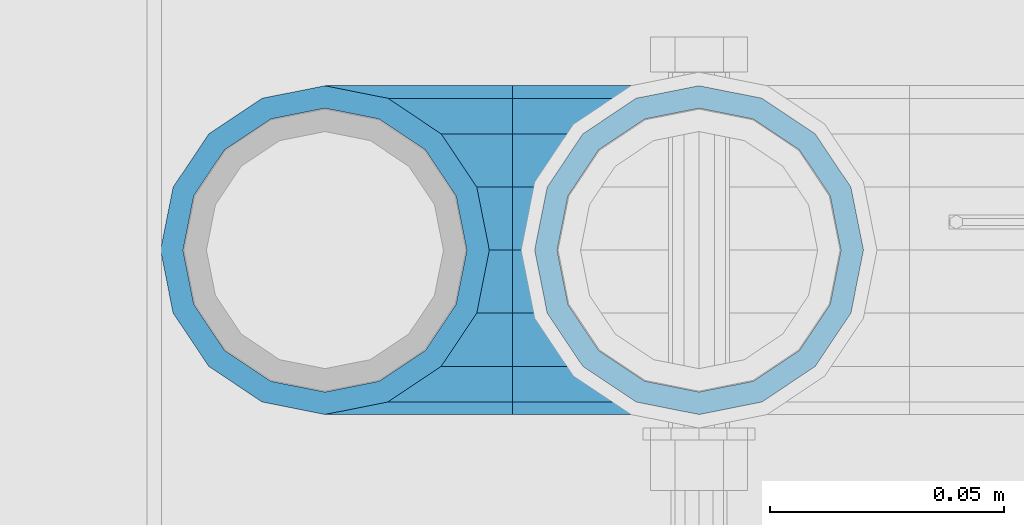
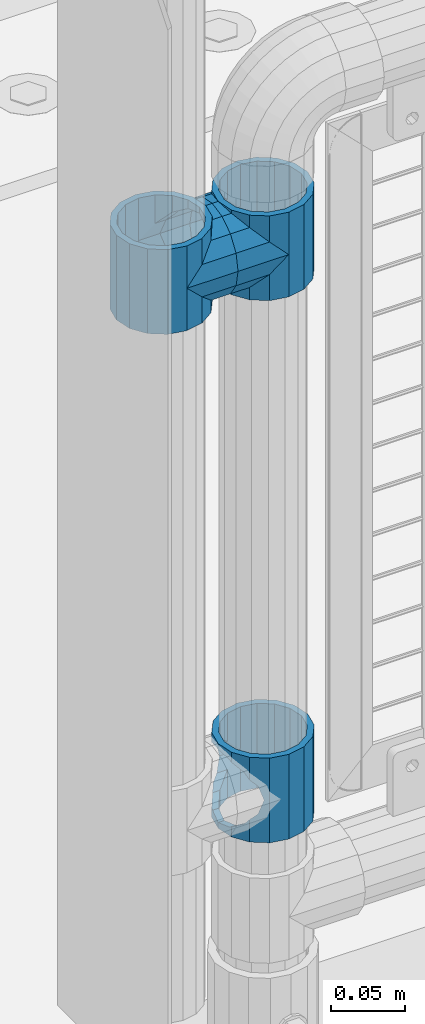
# One storey, part 117 of 208: 5 beams.
"""IFC2X3 building model written with IfcOpenShell, lengths in millimetres."""

from ifc_helpers import new_model, si_unit, frame, origin_with_axes, place, context, subcontext, project, spatial, faceted_brep, material, type_object, element, save


model = new_model("IFC2X3")

# Units and contexts
model_context = context("Model", 3, precision=1e-05, world=origin_with_axes())
body_context = subcontext(model_context, "Body", "Model", "MODEL_VIEW")
ifc_project = project(units=[si_unit("LENGTHUNIT", "METRE", prefix="MILLI"), si_unit("AREAUNIT", "SQUARE_METRE"), si_unit("VOLUMEUNIT", "CUBIC_METRE"), si_unit("MASSUNIT", "GRAM", prefix="KILO"), si_unit("TIMEUNIT", "SECOND"), si_unit("PLANEANGLEUNIT", "RADIAN"), si_unit("SOLIDANGLEUNIT", "STERADIAN"), si_unit("THERMODYNAMICTEMPERATUREUNIT", "DEGREE_CELSIUS"), si_unit("LUMINOUSINTENSITYUNIT", "LUMEN")], contexts=[model_context])

# Site, building, storey
site_placement = place(None, origin_with_axes())
site = spatial("IfcSite", under=ifc_project, at=site_placement, CompositionType="ELEMENT")
building_placement = place(site_placement, origin_with_axes())
building = spatial("IfcBuilding", under=site, at=building_placement, Name="Standard", CompositionType="ELEMENT")
storey_placement = place(building_placement, origin_with_axes())
storey = spatial("IfcBuildingStorey", under=building, at=storey_placement, Name="Undefined", CompositionType="ELEMENT", Elevation=0.0)

# Beams
ifc_material = material(Name="Misc_Undefined")
beam_type = type_object("IfcBeamType", PredefinedType="NOTDEFINED")
beam_1_placement = place(storey_placement, frame((-41829.0, 4664.5, 433.820000000001), z_axis=(1.0, 0.0, 0.0), x_axis=(0.0, 0.0, -1.0)))
element("IfcBeam", 1, at=beam_1_placement, inside=storey, type_object=beam_type, material=ifc_material, context=body_context, shape_type="Brep", body=[
    faceted_brep([(56.6106908090114, 21.4606908090118, -27.1226768591077), (56.6106908090114, 21.4606908090118, -21.4606908090136), (46.7644421722801, 28.0397438117179, -11.6144421722784), (46.7644421722801, 28.0397438117179, -20.0882031229921), (51.531042408003, 24.8548033587067, -24.8548033587067), (63.1897438117172, 11.6144421722802, -32.8397438117245), (63.1897438117172, 11.6144421722802, -28.0397438117143), (61.962379517676, 13.4513226476329, -32.4743655677739), (65.4999999999997, 0.0, -35.1500000000015), (65.4999999999997, 0.0, -30.3499999999985), (63.1897438117172, -11.6144421722802, -32.8397438117245), (63.1897438117172, -11.6144421722802, -28.0397438117143), (61.962379517675, -13.4513226476329, -32.4743655677739), (56.6106908090114, -21.4606908090118, -27.1226768591005), (56.6106908090114, -21.4606908090118, -21.4606908090136), (51.531042408003, -24.8548033587067, -24.8548033587067), (46.7644421722801, -28.0397438117179, -20.0882031229921), (46.7644421722801, -28.0397438117179, -11.6144421722784), (35.1499999999996, -30.3500000000004, -16.6306603983685), (35.1500000000015, -30.35, 0.0), (23.5355578277191, -28.0397438117179, -20.0882031229921), (23.5355578277191, -28.0397438117179, -11.6144421722784), (13.6893091909879, -21.4606908090118, -27.1226768591005), (13.6893091909879, -21.4606908090118, -21.4606908090136), (18.7689575919962, -24.8548033587067, -24.8548033587067), (7.11025618828205, -11.6144421722802, -32.8397438117245), (7.11025618828205, -11.6144421722802, -28.0397438117143), (8.33762048232325, -13.4513226476329, -32.4743655677739), (4.79999999999961, 0.0, -35.1500000000015), (4.79999999999961, 0.0, -30.3499999999985), (7.11025618828211, 11.6144421722802, -32.8397438117245), (7.11025618828211, 11.6144421722802, -28.0397438117143), (8.33762048232325, 13.4513226476329, -32.4743655677739), (13.6893091909879, 21.4606908090118, -27.1226768591077), (13.6893091909879, 21.4606908090118, -21.4606908090136), (18.7689575919962, 24.8548033587067, -24.8548033587067), (23.5355578277192, 28.0397438117179, -20.0882031229921), (23.5355578277192, 28.0397438117179, -11.6144421722784), (35.1499999999996, 30.3500000000004, -16.6306603983685), (35.1500000000015, 30.35, 0.0), (0.0, 32.4743655677721, -13.4513226476338), (0.0, 35.1499999999996, 0.0), (70.2999999999993, 35.1499999999996, 0.0), (70.2999999999993, 32.4743655677721, -13.4513226476338), (0.0, 32.4743655677721, 13.4513226476338), (70.2999999999993, 32.4743655677721, 13.4513226476338), (0.0, 24.8548033587067, 24.8548033587067), (70.2999999999993, 24.8548033587067, 24.8548033587067), (0.0, 13.4513226476329, 32.4743655677739), (70.2999999999993, 13.4513226476329, 32.4743655677739), (0.0, 0.0, 35.1499999999996), (70.2999999999993, 0.0, 35.1500000000015), (0.0, -13.4513226476329, 32.4743655677739), (70.2999999999993, -13.4513226476329, 32.4743655677739), (0.0, -24.8548033587067, 24.8548033587067), (70.2999999999993, -24.8548033587067, 24.8548033587067), (0.0, -32.4743655677721, 13.4513226476338), (70.2999999999993, -32.4743655677721, 13.4513226476338), (0.0, -35.1499999999996, 0.0), (70.2999999999993, -35.1499999999996, 0.0), (70.2999999999993, -30.3500000000004, 0.0), (70.2999999999993, -28.0397438117179, -11.6144421722784), (70.2999999999993, -21.4606908090118, -21.4606908090136), (70.2999999999993, -11.6144421722802, -28.0397438117143), (70.2999999999993, 0.0, -30.3499999999985), (70.2999999999993, 11.6144421722802, -28.0397438117143), (70.2999999999993, 21.4606908090118, -21.4606908090136), (70.2999999999993, 28.0397438117179, -11.6144421722784), (0.0, -28.0397438117179, -11.6144421722784), (0.0, -30.3500000000004, 0.0), (0.0, -21.4606908090118, -21.4606908090136), (0.0, -11.6144421722802, -28.0397438117143), (0.0, 0.0, -30.3499999999985), (0.0, 11.6144421722802, -28.0397438117143), (0.0, 21.4606908090118, -21.4606908090136), (0.0, 28.0397438117179, -11.6144421722784), (0.0, 30.3500000000004, 0.0), (70.2999999999993, 30.3500000000004, 0.0), (0.0, 28.0397438117179, 11.6144421722784), (70.2999999999993, 28.0397438117179, 11.6144421722784), (0.0, 21.4606908090118, 21.4606908090136), (70.2999999999993, 21.4606908090118, 21.4606908090136), (0.0, 11.6144421722802, 28.0397438117143), (70.2999999999993, 11.6144421722802, 28.0397438117143), (0.0, 0.0, 30.3499999999985), (70.2999999999993, 0.0, 30.3499999999985), (0.0, -11.6144421722802, 28.0397438117143), (70.2999999999993, -11.6144421722802, 28.0397438117143), (0.0, -21.4606908090118, 21.4606908090136), (70.2999999999993, -21.4606908090118, 21.4606908090136), (0.0, -28.0397438117179, 11.6144421722784), (70.2999999999993, -28.0397438117179, 11.6144421722784), (70.2999999999993, -24.8548033587067, -24.8548033587067), (70.2999999999993, -13.4513226476329, -32.4743655677739), (70.2999999999993, 0.0, -35.1500000000015), (70.2999999999993, 13.4513226476329, -32.4743655677739), (70.2999999999993, 24.8548033587067, -24.8548033587067), (70.2999999999993, -32.4743655677721, -13.4513226476338), (0.0, -32.4743655677721, -13.4513226476338), (0.0, 24.8548033587067, -24.8548033587067), (0.0, 13.4513226476329, -32.4743655677739), (0.0, 0.0, -35.1499999999996), (0.0, -13.4513226476329, -32.4743655677739), (0.0, -24.8548033587067, -24.8548033587067)], [[[0, 1, 2, 3, 4]], [[5, 6, 1, 0, 7]], [[8, 9, 6, 5]], [[10, 11, 9, 8]], [[12, 13, 14, 11, 10]], [[15, 16, 17, 14, 13]], [[18, 19, 17, 16]], [[20, 21, 19, 18]], [[22, 23, 21, 20, 24]], [[25, 26, 23, 22, 27]], [[28, 29, 26, 25]], [[30, 31, 29, 28]], [[32, 33, 34, 31, 30]], [[35, 36, 37, 34, 33]], [[38, 39, 37, 36]], [[3, 2, 39, 38]], [[40, 41, 42, 43]], [[41, 44, 45, 42]], [[44, 46, 47, 45]], [[46, 48, 49, 47]], [[48, 50, 51, 49]], [[50, 52, 53, 51]], [[52, 54, 55, 53]], [[54, 56, 57, 55]], [[56, 58, 59, 57]], [[60, 61, 17, 19]], [[61, 62, 14, 17]], [[62, 63, 11, 14]], [[63, 64, 9, 11]], [[64, 65, 6, 9]], [[65, 66, 1, 6]], [[66, 67, 2, 1]], [[68, 69, 19, 21]], [[70, 68, 21, 23]], [[71, 70, 23, 26]], [[72, 71, 26, 29]], [[73, 72, 29, 31]], [[74, 73, 31, 34]], [[75, 74, 34, 37]], [[76, 75, 37, 39]], [[67, 77, 39, 2]], [[78, 76, 39, 77, 79]], [[80, 78, 79, 81]], [[82, 80, 81, 83]], [[84, 82, 83, 85]], [[86, 84, 85, 87]], [[88, 86, 87, 89]], [[90, 88, 89, 91]], [[19, 69, 90, 91, 60]], [[92, 93, 94, 95, 96, 43, 42, 45, 47, 49, 51, 53, 55, 57, 59, 97], [89, 87, 85, 83, 81, 79, 77, 67, 66, 65, 64, 63, 62, 61, 60, 91]], [[58, 98, 97, 59]], [[56, 54, 52, 50, 48, 46, 44, 41, 40, 99, 100, 101, 102, 103, 98, 58], [68, 70, 71, 72, 73, 74, 75, 76, 78, 80, 82, 84, 86, 88, 90, 69]], [[100, 99, 35, 33, 32]], [[101, 100, 32, 30, 28]], [[27, 102, 101, 28, 25]], [[24, 103, 102, 27, 22]], [[92, 97, 98, 103, 24, 20, 18, 16, 15]], [[93, 92, 15, 13, 12]], [[94, 93, 12, 10, 8]], [[7, 95, 94, 8, 5]], [[4, 96, 95, 7, 0]], [[38, 36, 35, 99, 40, 43, 96, 4, 3]]]),
])
beam_2_placement = place(storey_placement, frame((-41909.0, 4664.5, 848.67), z_axis=(0.0, -1.0, 0.0), x_axis=(1.0, 0.0, 0.0)))
element("IfcBeam", 2, at=beam_2_placement, inside=storey, type_object=beam_type, material=ifc_material, context=body_context, shape_type="Brep", body=[
    faceted_brep([(13.4513226476338, -13.4513226476329, -32.4743655677721), (13.4513226476338, 13.4513226476329, -32.4743655677721), (0.0, 0.0, -35.1499999999996), (27.1226768591005, 21.4606908090117, 21.4606908090118), (24.8548033587067, 16.3810424080032, 24.8548033587067), (24.8548033587067, 24.8548033587072, 24.8548033587067), (32.4743655677739, 32.4743655677717, 13.4513226476329), (32.4743655677739, 26.812379517676, 13.4513226476329), (0.0, 0.0, 35.1499999999996), (13.4513226476338, 13.4513226476329, 32.4743655677721), (13.4513226476338, -13.4513226476329, 32.4743655677721), (20.0882031229921, 11.6144421722805, 28.0397438117179), (16.6306603983685, 0.0, 30.3500000000004), (20.0882031229921, -11.6144421722805, 28.0397438117179), (24.8548033587067, -16.3810424080039, 24.8548033587067), (24.8548033587067, -24.8548033587072, 24.8548033587067), (27.1226768591005, -21.4606908090117, 21.4606908090118), (32.4743655677739, -26.8123795176755, 13.4513226476329), (32.4743655677739, -32.4743655677717, 13.4513226476329), (32.8397438117172, -28.0397438117175, 11.6144421722802), (35.1500000000015, -30.35, 0.0), (35.1500000000015, -35.1499999999996, 0.0), (32.8397438117172, -28.0397438117175, -11.6144421722802), (32.4743655677739, -26.8123795176766, -13.4513226476329), (32.4743655677739, -32.4743655677717, -13.4513226476329), (27.1226768591077, -21.4606908090117, -21.4606908090118), (24.8548033587067, -16.3810424080039, -24.8548033587067), (24.8548033587067, -24.8548033587072, -24.8548033587067), (20.0882031229849, -11.6144421722805, -28.0397438117179), (16.6306603983685, 0.0, -30.3500000000004), (20.0882031229849, 11.6144421722805, -28.0397438117179), (24.8548033587067, 16.3810424080023, -24.8548033587067), (24.8548033587067, 24.8548033587072, -24.8548033587067), (32.4743655677739, 26.8123795176755, -13.4513226476329), (32.4743655677739, 32.4743655677717, -13.4513226476329), (27.1226768591077, 21.4606908090117, -21.4606908090118), (35.1500000000015, 30.35, 0.0), (35.1500000000015, 35.15, 0.0), (32.8397438117172, 28.0397438117175, -11.6144421722802), (32.8397438117172, 28.0397438117175, 11.6144421722802), (40.1500000000015, -35.15, 0.0), (40.1500000000015, -32.4743655677717, 13.4513226476329), (40.1500000000015, -24.8548033587072, 24.8548033587067), (40.1500000000015, -13.4513226476329, 32.4743655677721), (40.1500000000015, 0.0, 35.1499999999996), (40.1500000000015, 13.4513226476329, 32.4743655677721), (40.1500000000015, 24.8548033587072, 24.8548033587067), (40.1500000000015, 32.4743655677717, 13.4513226476329), (40.1500000000015, 35.15, 0.0), (40.1500000000015, -24.8548033587072, -24.8548033587067), (40.1500000000015, -32.4743655677717, -13.4513226476329), (40.1500000000015, -13.4513226476329, -32.4743655677721), (40.1500000000015, 0.0, -35.1499999999996), (40.1500000000015, 13.4513226476329, -32.4743655677721), (40.1500000000015, 24.8548033587072, -24.8548033587067), (40.1500000000015, 32.4743655677717, -13.4513226476329), (40.1500000000015, -21.4606908090117, 21.4606908090118), (40.1500000000015, -11.6144421722805, 28.0397438117179), (40.1500000000015, 0.0, 30.3500000000004), (40.1500000000015, 11.6144421722805, 28.0397438117179), (40.1500000000015, 21.4606908090117, 21.4606908090118), (40.1500000000015, 28.0397438117175, 11.6144421722802), (40.1500000000015, 30.35, 0.0), (40.1500000000015, 28.0397438117175, -11.6144421722802), (40.1500000000015, 21.4606908090117, -21.4606908090118), (40.1500000000015, 11.6144421722805, -28.0397438117179), (40.1500000000015, 0.0, -30.3500000000004), (40.1500000000015, -11.6144421722805, -28.0397438117179), (40.1500000000015, -21.4606908090117, -21.4606908090118), (40.1500000000015, -28.0397438117175, -11.6144421722802), (40.1500000000015, -30.35, 0.0), (40.1500000000015, -28.0397438117175, 11.6144421722802)], [[[0, 1, 2]], [[3, 4, 5, 6, 7]], [[8, 9, 10]], [[10, 9, 5, 4, 11, 12, 13, 14, 15]], [[15, 14, 16, 17, 18]], [[18, 17, 19, 20, 21]], [[21, 20, 22, 23, 24]], [[24, 23, 25, 26, 27]], [[27, 26, 28, 29, 30, 31, 32, 1, 0]], [[33, 34, 32, 31, 35]], [[36, 37, 34, 33, 38]], [[39, 7, 6, 37, 36]], [[40, 41, 18, 21]], [[41, 42, 15, 18]], [[42, 43, 10, 15]], [[43, 44, 8, 10]], [[44, 45, 9, 8]], [[45, 46, 5, 9]], [[46, 47, 6, 5]], [[47, 48, 37, 6]], [[49, 50, 24, 27]], [[51, 49, 27, 0]], [[52, 51, 0, 2]], [[53, 52, 2, 1]], [[54, 53, 1, 32]], [[55, 54, 32, 34]], [[48, 55, 34, 37]], [[50, 40, 21, 24]], [[49, 51, 52, 53, 54, 55, 48, 47, 46, 45, 44, 43, 42, 41, 40, 50], [56, 57, 58, 59, 60, 61, 62, 63, 64, 65, 66, 67, 68, 69, 70, 71]], [[63, 62, 36, 38]], [[35, 64, 63, 38, 33]], [[30, 65, 64, 35, 31]], [[66, 65, 30, 29]], [[67, 66, 29, 28]], [[68, 67, 28, 26, 25]], [[69, 68, 25, 23, 22]], [[70, 69, 22, 20]], [[71, 70, 20, 19]], [[16, 56, 71, 19, 17]], [[13, 57, 56, 16, 14]], [[58, 57, 13, 12]], [[59, 58, 12, 11]], [[60, 59, 11, 4, 3]], [[61, 60, 3, 7, 39]], [[62, 61, 39, 36]]]),
])
beam_3_placement = place(storey_placement, frame((-41829.0, 4664.5, 848.67), z_axis=(0.0, 1.0, 0.0), x_axis=(-1.0, 0.0, 0.0)))
element("IfcBeam", 3, at=beam_3_placement, inside=storey, type_object=beam_type, material=ifc_material, context=body_context, shape_type="Brep", body=[
    faceted_brep([(13.4513226476338, -13.4513226476329, -32.4743655677721), (13.4513226476338, 13.4513226476329, -32.4743655677721), (0.0, 0.0, -35.1499999999996), (24.8548033587067, -24.8548033587072, 24.8548033587067), (24.8548033587067, -16.3810424080039, 24.8548033587067), (27.1226768591005, -21.4606908090117, 21.4606908090118), (32.4743655677739, -26.8123795176755, 13.4513226476329), (32.4743655677739, -32.4743655677717, 13.4513226476329), (32.8397438117172, -28.0397438117175, 11.6144421722802), (35.1500000000015, -30.35, 0.0), (35.1500000000015, -35.1499999999996, 0.0), (32.8397438117172, -28.0397438117175, -11.6144421722802), (32.4743655677739, -26.8123795176766, -13.4513226476329), (32.4743655677739, -32.4743655677717, -13.4513226476329), (27.1226768591077, -21.4606908090117, -21.4606908090118), (24.8548033587067, -16.3810424080039, -24.8548033587067), (24.8548033587067, -24.8548033587072, -24.8548033587067), (20.0882031229849, -11.6144421722805, -28.0397438117179), (16.6306603983685, 0.0, -30.3500000000004), (20.0882031229849, 11.6144421722805, -28.0397438117179), (24.8548033587067, 16.3810424080023, -24.8548033587067), (24.8548033587067, 24.8548033587072, -24.8548033587067), (32.4743655677739, 26.8123795176755, -13.4513226476329), (32.4743655677739, 32.4743655677717, -13.4513226476329), (27.1226768591077, 21.4606908090117, -21.4606908090118), (35.1500000000015, 30.35, 0.0), (35.1500000000015, 35.15, 0.0), (32.8397438117172, 28.0397438117175, -11.6144421722802), (32.8397438117172, 28.0397438117175, 11.6144421722802), (32.4743655677739, 26.812379517676, 13.4513226476329), (32.4743655677739, 32.4743655677717, 13.4513226476329), (27.1226768591005, 21.4606908090117, 21.4606908090118), (24.8548033587067, 16.3810424080032, 24.8548033587067), (24.8548033587067, 24.8548033587072, 24.8548033587067), (0.0, 0.0, 35.1499999999996), (13.4513226476338, 13.4513226476329, 32.4743655677721), (13.4513226476338, -13.4513226476329, 32.4743655677721), (20.0882031229921, 11.6144421722805, 28.0397438117179), (16.6306603983685, 0.0, 30.3500000000004), (20.0882031229921, -11.6144421722805, 28.0397438117179), (40.1500000000015, -35.15, 0.0), (40.1500000000015, -32.4743655677717, 13.4513226476329), (40.1500000000015, -24.8548033587072, 24.8548033587067), (40.1500000000015, -13.4513226476329, 32.4743655677721), (40.1500000000015, 0.0, 35.1499999999996), (40.1500000000015, -24.8548033587072, -24.8548033587067), (40.1500000000015, -32.4743655677717, -13.4513226476329), (40.1500000000015, -13.4513226476329, -32.4743655677721), (40.1500000000015, 0.0, -35.1499999999996), (40.1500000000015, 13.4513226476329, -32.4743655677721), (40.1500000000015, 24.8548033587072, -24.8548033587067), (40.1500000000015, 32.4743655677717, -13.4513226476329), (40.1500000000015, 35.15, 0.0), (40.1500000000015, 32.4743655677717, 13.4513226476329), (40.1500000000015, 24.8548033587072, 24.8548033587067), (40.1500000000015, 13.4513226476329, 32.4743655677721), (40.1500000000015, -21.4606908090117, 21.4606908090118), (40.1500000000015, -11.6144421722805, 28.0397438117179), (40.1500000000015, 0.0, 30.3500000000004), (40.1500000000015, 11.6144421722805, 28.0397438117179), (40.1500000000015, 21.4606908090117, 21.4606908090118), (40.1500000000015, 28.0397438117175, 11.6144421722802), (40.1500000000015, 30.35, 0.0), (40.1500000000015, 28.0397438117175, -11.6144421722802), (40.1500000000015, 21.4606908090117, -21.4606908090118), (40.1500000000015, 11.6144421722805, -28.0397438117179), (40.1500000000015, 0.0, -30.3500000000004), (40.1500000000015, -11.6144421722805, -28.0397438117179), (40.1500000000015, -21.4606908090117, -21.4606908090118), (40.1500000000015, -28.0397438117175, -11.6144421722802), (40.1500000000015, -30.35, 0.0), (40.1500000000015, -28.0397438117175, 11.6144421722802)], [[[0, 1, 2]], [[3, 4, 5, 6, 7]], [[7, 6, 8, 9, 10]], [[10, 9, 11, 12, 13]], [[13, 12, 14, 15, 16]], [[16, 15, 17, 18, 19, 20, 21, 1, 0]], [[22, 23, 21, 20, 24]], [[25, 26, 23, 22, 27]], [[28, 29, 30, 26, 25]], [[31, 32, 33, 30, 29]], [[34, 35, 36]], [[36, 35, 33, 32, 37, 38, 39, 4, 3]], [[40, 41, 7, 10]], [[41, 42, 3, 7]], [[42, 43, 36, 3]], [[43, 44, 34, 36]], [[45, 46, 13, 16]], [[47, 45, 16, 0]], [[48, 47, 0, 2]], [[49, 48, 2, 1]], [[50, 49, 1, 21]], [[51, 50, 21, 23]], [[52, 51, 23, 26]], [[53, 52, 26, 30]], [[54, 53, 30, 33]], [[55, 54, 33, 35]], [[44, 55, 35, 34]], [[46, 40, 10, 13]], [[45, 47, 48, 49, 50, 51, 52, 53, 54, 55, 44, 43, 42, 41, 40, 46], [56, 57, 58, 59, 60, 61, 62, 63, 64, 65, 66, 67, 68, 69, 70, 71]], [[59, 58, 38, 37]], [[60, 59, 37, 32, 31]], [[61, 60, 31, 29, 28]], [[62, 61, 28, 25]], [[63, 62, 25, 27]], [[24, 64, 63, 27, 22]], [[19, 65, 64, 24, 20]], [[66, 65, 19, 18]], [[67, 66, 18, 17]], [[68, 67, 17, 15, 14]], [[69, 68, 14, 12, 11]], [[70, 69, 11, 9]], [[71, 70, 9, 8]], [[5, 56, 71, 8, 6]], [[39, 57, 56, 5, 4]], [[58, 57, 39, 38]]]),
])
beam_4_placement = place(storey_placement, frame((-41909.0, 4664.5, 883.82), z_axis=(-1.0, 0.0, 0.0), x_axis=(0.0, 0.0, -1.0)))
element("IfcBeam", 4, at=beam_4_placement, inside=storey, type_object=beam_type, material=ifc_material, context=body_context, shape_type="Brep", body=[
    faceted_brep([(7.11025618828205, -11.6144421722802, -32.8397438117245), (7.11025618828205, -11.6144421722802, -28.0397438117143), (13.6893091909879, -21.4606908090118, -21.4606908090136), (13.6893091909879, -21.4606908090118, -27.1226768591005), (8.33762048232325, -13.4513226476329, -32.4743655677739), (23.5355578277191, -28.0397438117179, -11.6144421722784), (23.5355578277191, -28.0397438117179, -20.0882031229921), (18.7689575919962, -24.8548033587067, -24.8548033587067), (35.1500000000015, -30.35, 0.0), (35.1499999999996, -30.3500000000004, -16.6306603983685), (46.7644421722801, -28.0397438117179, -11.6144421722784), (46.7644421722801, -28.0397438117179, -20.0882031229921), (51.531042408003, -24.8548033587067, -24.8548033587067), (56.6106908090114, -21.4606908090118, -21.4606908090136), (56.6106908090114, -21.4606908090118, -27.1226768591005), (61.962379517675, -13.4513226476329, -32.4743655677739), (63.1897438117172, -11.6144421722802, -28.0397438117143), (63.1897438117172, -11.6144421722802, -32.8397438117245), (65.4999999999997, 0.0, -30.3499999999985), (65.4999999999997, 0.0, -35.1500000000015), (63.1897438117172, 11.6144421722802, -28.0397438117143), (63.1897438117172, 11.6144421722802, -32.8397438117245), (56.6106908090114, 21.4606908090118, -21.4606908090136), (56.6106908090114, 21.4606908090118, -27.1226768591077), (61.962379517676, 13.4513226476329, -32.4743655677739), (46.7644421722801, 28.0397438117179, -11.6144421722784), (46.7644421722801, 28.0397438117179, -20.0882031229921), (51.531042408003, 24.8548033587067, -24.8548033587067), (35.1500000000015, 30.35, 0.0), (35.1499999999996, 30.3500000000004, -16.6306603983685), (23.5355578277192, 28.0397438117179, -11.6144421722784), (23.5355578277192, 28.0397438117179, -20.0882031229921), (18.7689575919962, 24.8548033587067, -24.8548033587067), (13.6893091909879, 21.4606908090118, -21.4606908090136), (13.6893091909879, 21.4606908090118, -27.1226768591077), (8.33762048232325, 13.4513226476329, -32.4743655677739), (7.11025618828211, 11.6144421722802, -28.0397438117143), (7.11025618828211, 11.6144421722802, -32.8397438117245), (4.79999999999961, 0.0, -30.3499999999985), (4.79999999999961, 0.0, -35.1500000000015), (0.0, 21.4606908090118, 21.4606908090136), (0.0, 28.0397438117179, 11.6144421722784), (70.2999999999993, 28.0397438117179, 11.6144421722784), (70.2999999999993, 21.4606908090118, 21.4606908090136), (0.0, 11.6144421722802, 28.0397438117143), (70.2999999999993, 11.6144421722802, 28.0397438117143), (0.0, 0.0, 30.3499999999985), (70.2999999999993, 0.0, 30.3499999999985), (0.0, -11.6144421722802, 28.0397438117143), (70.2999999999993, -11.6144421722802, 28.0397438117143), (0.0, -21.4606908090118, 21.4606908090136), (70.2999999999993, -21.4606908090118, 21.4606908090136), (0.0, -28.0397438117179, 11.6144421722784), (70.2999999999993, -28.0397438117179, 11.6144421722784), (0.0, -24.8548033587067, -24.8548033587067), (0.0, -13.4513226476329, -32.4743655677739), (0.0, 0.0, -35.1499999999996), (0.0, -32.4743655677721, 13.4513226476338), (0.0, -35.1499999999996, 0.0), (70.2999999999993, -35.1499999999996, 0.0), (70.2999999999993, -32.4743655677721, 13.4513226476338), (0.0, -24.8548033587067, 24.8548033587067), (70.2999999999993, -24.8548033587067, 24.8548033587067), (0.0, -13.4513226476329, 32.4743655677739), (70.2999999999993, -13.4513226476329, 32.4743655677739), (0.0, 0.0, 35.1499999999996), (70.2999999999993, 0.0, 35.1500000000015), (0.0, 13.4513226476329, 32.4743655677739), (70.2999999999993, 13.4513226476329, 32.4743655677739), (0.0, 24.8548033587067, 24.8548033587067), (70.2999999999993, 24.8548033587067, 24.8548033587067), (0.0, 32.4743655677721, 13.4513226476338), (70.2999999999993, 32.4743655677721, 13.4513226476338), (0.0, 35.1499999999996, 0.0), (70.2999999999993, 35.1499999999996, 0.0), (0.0, 32.4743655677721, -13.4513226476338), (70.2999999999993, 32.4743655677721, -13.4513226476338), (70.2999999999993, -13.4513226476329, -32.4743655677739), (70.2999999999993, -24.8548033587067, -24.8548033587067), (70.2999999999993, 0.0, -35.1500000000015), (70.2999999999993, 13.4513226476329, -32.4743655677739), (70.2999999999993, 24.8548033587067, -24.8548033587067), (0.0, 24.8548033587067, -24.8548033587067), (0.0, 13.4513226476329, -32.4743655677739), (70.2999999999993, -32.4743655677721, -13.4513226476338), (0.0, -32.4743655677721, -13.4513226476338), (0.0, -28.0397438117179, -11.6144421722784), (0.0, -21.4606908090118, -21.4606908090136), (0.0, -11.6144421722802, -28.0397438117143), (0.0, 0.0, -30.3499999999985), (0.0, 11.6144421722802, -28.0397438117143), (0.0, 21.4606908090118, -21.4606908090136), (0.0, 28.0397438117179, -11.6144421722784), (0.0, 30.3500000000004, 0.0), (0.0, -30.3500000000004, 0.0), (70.2999999999993, 30.3500000000004, 0.0), (70.2999999999993, 28.0397438117179, -11.6144421722784), (70.2999999999993, 21.4606908090118, -21.4606908090136), (70.2999999999993, 11.6144421722802, -28.0397438117143), (70.2999999999993, 0.0, -30.3499999999985), (70.2999999999993, -11.6144421722802, -28.0397438117143), (70.2999999999993, -21.4606908090118, -21.4606908090136), (70.2999999999993, -28.0397438117179, -11.6144421722784), (70.2999999999993, -30.3500000000004, 0.0)], [[[0, 1, 2, 3, 4]], [[3, 2, 5, 6, 7]], [[6, 5, 8, 9]], [[9, 8, 10, 11]], [[12, 11, 10, 13, 14]], [[15, 14, 13, 16, 17]], [[17, 16, 18, 19]], [[19, 18, 20, 21]], [[21, 20, 22, 23, 24]], [[23, 22, 25, 26, 27]], [[26, 25, 28, 29]], [[29, 28, 30, 31]], [[32, 31, 30, 33, 34]], [[35, 34, 33, 36, 37]], [[37, 36, 38, 39]], [[39, 38, 1, 0]], [[40, 41, 42, 43]], [[44, 40, 43, 45]], [[46, 44, 45, 47]], [[48, 46, 47, 49]], [[50, 48, 49, 51]], [[52, 50, 51, 53]], [[7, 54, 55, 4, 3]], [[4, 55, 56, 39, 0]], [[57, 58, 59, 60]], [[61, 57, 60, 62]], [[63, 61, 62, 64]], [[65, 63, 64, 66]], [[67, 65, 66, 68]], [[69, 67, 68, 70]], [[71, 69, 70, 72]], [[73, 71, 72, 74]], [[75, 73, 74, 76]], [[77, 78, 12, 14, 15]], [[79, 77, 15, 17, 19]], [[24, 80, 79, 19, 21]], [[27, 81, 80, 24, 23]], [[29, 31, 32, 82, 75, 76, 81, 27, 26]], [[83, 82, 32, 34, 35]], [[56, 83, 35, 37, 39]], [[78, 84, 85, 54, 7, 6, 9, 11, 12]], [[58, 85, 84, 59]], [[57, 61, 63, 65, 67, 69, 71, 73, 75, 82, 83, 56, 55, 54, 85, 58], [86, 87, 88, 89, 90, 91, 92, 93, 41, 40, 44, 46, 48, 50, 52, 94]], [[90, 89, 38, 36]], [[91, 90, 36, 33]], [[92, 91, 33, 30]], [[93, 92, 30, 28]], [[41, 93, 28, 95, 42]], [[96, 95, 28, 25]], [[97, 96, 25, 22]], [[98, 97, 22, 20]], [[99, 98, 20, 18]], [[100, 99, 18, 16]], [[101, 100, 16, 13]], [[102, 101, 13, 10]], [[103, 102, 10, 8]], [[78, 77, 79, 80, 81, 76, 74, 72, 70, 68, 66, 64, 62, 60, 59, 84], [51, 49, 47, 45, 43, 42, 95, 96, 97, 98, 99, 100, 101, 102, 103, 53]], [[8, 94, 52, 53, 103]], [[86, 94, 8, 5]], [[87, 86, 5, 2]], [[88, 87, 2, 1]], [[89, 88, 1, 38]]]),
])
beam_5_placement = place(storey_placement, frame((-41829.0, 4664.5, 883.82), z_axis=(1.0, 0.0, 0.0), x_axis=(0.0, 0.0, -1.0)))
element("IfcBeam", 5, at=beam_5_placement, inside=storey, type_object=beam_type, material=ifc_material, context=body_context, shape_type="Brep", body=[
    faceted_brep([(56.6106908090114, 21.4606908090118, -27.1226768591077), (56.6106908090114, 21.4606908090118, -21.4606908090136), (46.7644421722801, 28.0397438117179, -11.6144421722784), (46.7644421722801, 28.0397438117179, -20.0882031229921), (51.531042408003, 24.8548033587067, -24.8548033587067), (63.1897438117172, 11.6144421722802, -32.8397438117245), (63.1897438117172, 11.6144421722802, -28.0397438117143), (61.962379517676, 13.4513226476329, -32.4743655677739), (65.4999999999997, 0.0, -35.1500000000015), (65.4999999999997, 0.0, -30.3499999999985), (63.1897438117172, -11.6144421722802, -32.8397438117245), (63.1897438117172, -11.6144421722802, -28.0397438117143), (61.962379517675, -13.4513226476329, -32.4743655677739), (56.6106908090114, -21.4606908090118, -27.1226768591005), (56.6106908090114, -21.4606908090118, -21.4606908090136), (51.531042408003, -24.8548033587067, -24.8548033587067), (46.7644421722801, -28.0397438117179, -20.0882031229921), (46.7644421722801, -28.0397438117179, -11.6144421722784), (35.1499999999996, -30.3500000000004, -16.6306603983685), (35.1500000000015, -30.35, 0.0), (23.5355578277191, -28.0397438117179, -20.0882031229921), (23.5355578277191, -28.0397438117179, -11.6144421722784), (13.6893091909879, -21.4606908090118, -27.1226768591005), (13.6893091909879, -21.4606908090118, -21.4606908090136), (18.7689575919962, -24.8548033587067, -24.8548033587067), (7.11025618828205, -11.6144421722802, -32.8397438117245), (7.11025618828205, -11.6144421722802, -28.0397438117143), (8.33762048232325, -13.4513226476329, -32.4743655677739), (4.79999999999961, 0.0, -35.1500000000015), (4.79999999999961, 0.0, -30.3499999999985), (7.11025618828211, 11.6144421722802, -32.8397438117245), (7.11025618828211, 11.6144421722802, -28.0397438117143), (8.33762048232325, 13.4513226476329, -32.4743655677739), (13.6893091909879, 21.4606908090118, -27.1226768591077), (13.6893091909879, 21.4606908090118, -21.4606908090136), (18.7689575919962, 24.8548033587067, -24.8548033587067), (23.5355578277192, 28.0397438117179, -20.0882031229921), (23.5355578277192, 28.0397438117179, -11.6144421722784), (35.1499999999996, 30.3500000000004, -16.6306603983685), (35.1500000000015, 30.35, 0.0), (0.0, 32.4743655677721, -13.4513226476338), (0.0, 35.1499999999996, 0.0), (70.2999999999993, 35.1499999999996, 0.0), (70.2999999999993, 32.4743655677721, -13.4513226476338), (0.0, 32.4743655677721, 13.4513226476338), (70.2999999999993, 32.4743655677721, 13.4513226476338), (0.0, 24.8548033587067, 24.8548033587067), (70.2999999999993, 24.8548033587067, 24.8548033587067), (0.0, 13.4513226476329, 32.4743655677739), (70.2999999999993, 13.4513226476329, 32.4743655677739), (0.0, 0.0, 35.1499999999996), (70.2999999999993, 0.0, 35.1500000000015), (0.0, -13.4513226476329, 32.4743655677739), (70.2999999999993, -13.4513226476329, 32.4743655677739), (0.0, -24.8548033587067, 24.8548033587067), (70.2999999999993, -24.8548033587067, 24.8548033587067), (0.0, -32.4743655677721, 13.4513226476338), (70.2999999999993, -32.4743655677721, 13.4513226476338), (0.0, -35.1499999999996, 0.0), (70.2999999999993, -35.1499999999996, 0.0), (70.2999999999993, -30.3500000000004, 0.0), (70.2999999999993, -28.0397438117179, -11.6144421722784), (70.2999999999993, -21.4606908090118, -21.4606908090136), (70.2999999999993, -11.6144421722802, -28.0397438117143), (70.2999999999993, 0.0, -30.3499999999985), (70.2999999999993, 11.6144421722802, -28.0397438117143), (70.2999999999993, 21.4606908090118, -21.4606908090136), (70.2999999999993, 28.0397438117179, -11.6144421722784), (0.0, -28.0397438117179, -11.6144421722784), (0.0, -30.3500000000004, 0.0), (0.0, -21.4606908090118, -21.4606908090136), (0.0, -11.6144421722802, -28.0397438117143), (0.0, 0.0, -30.3499999999985), (0.0, 11.6144421722802, -28.0397438117143), (0.0, 21.4606908090118, -21.4606908090136), (0.0, 28.0397438117179, -11.6144421722784), (0.0, 30.3500000000004, 0.0), (70.2999999999993, 30.3500000000004, 0.0), (0.0, 28.0397438117179, 11.6144421722784), (70.2999999999993, 28.0397438117179, 11.6144421722784), (0.0, 21.4606908090118, 21.4606908090136), (70.2999999999993, 21.4606908090118, 21.4606908090136), (0.0, 11.6144421722802, 28.0397438117143), (70.2999999999993, 11.6144421722802, 28.0397438117143), (0.0, 0.0, 30.3499999999985), (70.2999999999993, 0.0, 30.3499999999985), (0.0, -11.6144421722802, 28.0397438117143), (70.2999999999993, -11.6144421722802, 28.0397438117143), (0.0, -21.4606908090118, 21.4606908090136), (70.2999999999993, -21.4606908090118, 21.4606908090136), (0.0, -28.0397438117179, 11.6144421722784), (70.2999999999993, -28.0397438117179, 11.6144421722784), (70.2999999999993, -24.8548033587067, -24.8548033587067), (70.2999999999993, -13.4513226476329, -32.4743655677739), (70.2999999999993, 0.0, -35.1500000000015), (70.2999999999993, 13.4513226476329, -32.4743655677739), (70.2999999999993, 24.8548033587067, -24.8548033587067), (70.2999999999993, -32.4743655677721, -13.4513226476338), (0.0, -32.4743655677721, -13.4513226476338), (0.0, 24.8548033587067, -24.8548033587067), (0.0, 13.4513226476329, -32.4743655677739), (0.0, 0.0, -35.1499999999996), (0.0, -13.4513226476329, -32.4743655677739), (0.0, -24.8548033587067, -24.8548033587067)], [[[0, 1, 2, 3, 4]], [[5, 6, 1, 0, 7]], [[8, 9, 6, 5]], [[10, 11, 9, 8]], [[12, 13, 14, 11, 10]], [[15, 16, 17, 14, 13]], [[18, 19, 17, 16]], [[20, 21, 19, 18]], [[22, 23, 21, 20, 24]], [[25, 26, 23, 22, 27]], [[28, 29, 26, 25]], [[30, 31, 29, 28]], [[32, 33, 34, 31, 30]], [[35, 36, 37, 34, 33]], [[38, 39, 37, 36]], [[3, 2, 39, 38]], [[40, 41, 42, 43]], [[41, 44, 45, 42]], [[44, 46, 47, 45]], [[46, 48, 49, 47]], [[48, 50, 51, 49]], [[50, 52, 53, 51]], [[52, 54, 55, 53]], [[54, 56, 57, 55]], [[56, 58, 59, 57]], [[60, 61, 17, 19]], [[61, 62, 14, 17]], [[62, 63, 11, 14]], [[63, 64, 9, 11]], [[64, 65, 6, 9]], [[65, 66, 1, 6]], [[66, 67, 2, 1]], [[68, 69, 19, 21]], [[70, 68, 21, 23]], [[71, 70, 23, 26]], [[72, 71, 26, 29]], [[73, 72, 29, 31]], [[74, 73, 31, 34]], [[75, 74, 34, 37]], [[76, 75, 37, 39]], [[67, 77, 39, 2]], [[78, 76, 39, 77, 79]], [[80, 78, 79, 81]], [[82, 80, 81, 83]], [[84, 82, 83, 85]], [[86, 84, 85, 87]], [[88, 86, 87, 89]], [[90, 88, 89, 91]], [[19, 69, 90, 91, 60]], [[92, 93, 94, 95, 96, 43, 42, 45, 47, 49, 51, 53, 55, 57, 59, 97], [89, 87, 85, 83, 81, 79, 77, 67, 66, 65, 64, 63, 62, 61, 60, 91]], [[58, 98, 97, 59]], [[56, 54, 52, 50, 48, 46, 44, 41, 40, 99, 100, 101, 102, 103, 98, 58], [68, 70, 71, 72, 73, 74, 75, 76, 78, 80, 82, 84, 86, 88, 90, 69]], [[100, 99, 35, 33, 32]], [[101, 100, 32, 30, 28]], [[27, 102, 101, 28, 25]], [[24, 103, 102, 27, 22]], [[92, 97, 98, 103, 24, 20, 18, 16, 15]], [[93, 92, 15, 13, 12]], [[94, 93, 12, 10, 8]], [[7, 95, 94, 8, 5]], [[4, 96, 95, 7, 0]], [[38, 36, 35, 99, 40, 43, 96, 4, 3]]]),
])

save(model, "model.ifc")
